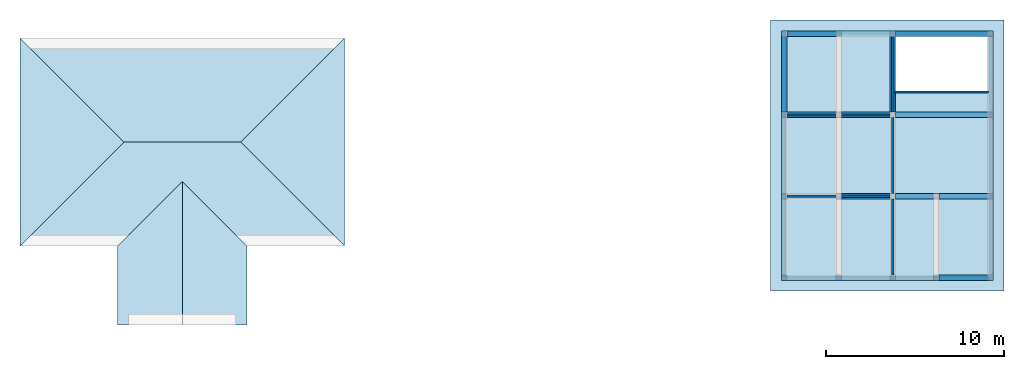
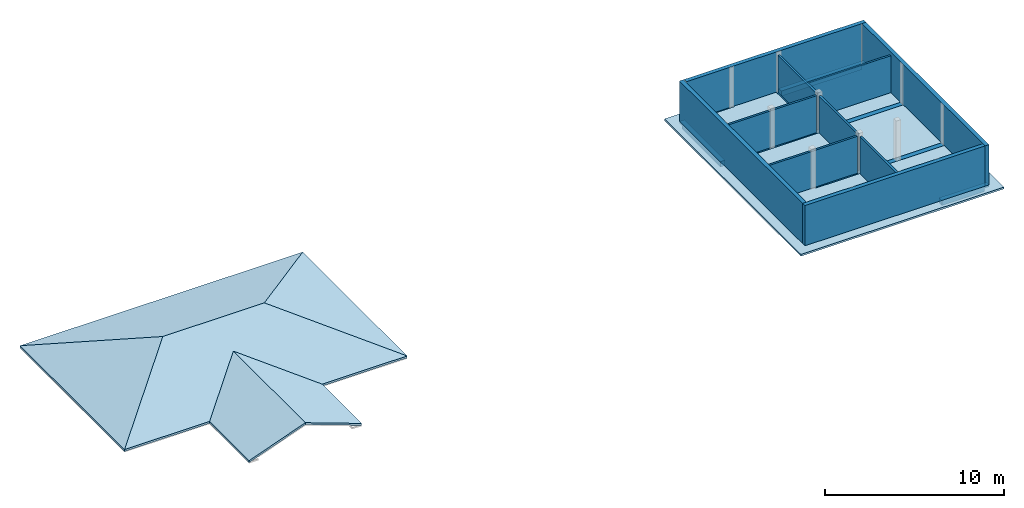
# One storey, part 2 of 3: 11 beams, 10 walls, 7 slabs, 1 opening, 1 element without a shape of its own.
"""IFC2X3 building model written with IfcOpenShell, lengths in feet."""

from ifc_helpers import new_model, entity, si_unit, converted_unit, derived_unit, direction, frame, frame_2d, origin, place, context, subcontext, project, spatial, polyline, rectangle, outline, extrude, faceted_brep, material, layer, layer_set, layer_usage, type_object, element, aggregate, save


model = new_model("IFC2X3")

# Units and contexts
model_context = context("Model", 3, precision=0.0001, world=origin(), true_north=direction((6.123031769111886e-17, 1.0)))
body_context = subcontext(model_context, "Body", "Model", "MODEL_VIEW")
ifc_project = project(units=[converted_unit("LENGTHUNIT", "FOOT", entity("IfcLengthMeasure", 0.3048), si_unit("LENGTHUNIT", "METRE"), dimensions=[1, 0, 0, 0, 0, 0, 0]), converted_unit("AREAUNIT", "SQUARE FOOT", entity("IfcAreaMeasure", 0.09290304), si_unit("AREAUNIT", "SQUARE_METRE"), dimensions=[2, 0, 0, 0, 0, 0, 0]), converted_unit("VOLUMEUNIT", "CUBIC FOOT", entity("IfcVolumeMeasure", 0.028316846592000004), si_unit("VOLUMEUNIT", "CUBIC_METRE"), dimensions=[3, 0, 0, 0, 0, 0, 0]), converted_unit("PLANEANGLEUNIT", "DEGREE", entity("IfcPlaneAngleMeasure", 0.017453292519943278), si_unit("PLANEANGLEUNIT", "RADIAN"), dimensions=[0, 0, 0, 0, 0, 0, 0]), si_unit("MASSUNIT", "GRAM", prefix="KILO"), derived_unit("MASSDENSITYUNIT", [(si_unit("MASSUNIT", "GRAM", prefix="KILO"), 1), (si_unit("LENGTHUNIT", "METRE"), -3)]), derived_unit("IONCONCENTRATIONUNIT", [(si_unit("MASSUNIT", "GRAM", prefix="KILO"), 1), (si_unit("LENGTHUNIT", "METRE"), -3)]), derived_unit("MOMENTOFINERTIAUNIT", [(si_unit("LENGTHUNIT", "METRE"), 4)]), si_unit("TIMEUNIT", "SECOND"), si_unit("FREQUENCYUNIT", "HERTZ"), si_unit("THERMODYNAMICTEMPERATUREUNIT", "DEGREE_CELSIUS"), derived_unit("THERMALTRANSMITTANCEUNIT", [(si_unit("MASSUNIT", "GRAM", prefix="KILO"), 1), (si_unit("THERMODYNAMICTEMPERATUREUNIT", "KELVIN"), -1), (si_unit("TIMEUNIT", "SECOND"), -3)]), derived_unit("THERMALCONDUCTANCEUNIT", [(si_unit("MASSUNIT", "GRAM", prefix="KILO"), 1), (si_unit("THERMODYNAMICTEMPERATUREUNIT", "KELVIN"), -1), (si_unit("TIMEUNIT", "SECOND"), -3), (si_unit("LENGTHUNIT", "METRE"), 1)]), derived_unit("VOLUMETRICFLOWRATEUNIT", [(si_unit("LENGTHUNIT", "METRE"), 3), (si_unit("TIMEUNIT", "SECOND"), -1)]), derived_unit("MASSFLOWRATEUNIT", [(si_unit("MASSUNIT", "GRAM", prefix="KILO"), 1), (si_unit("TIMEUNIT", "SECOND"), -1)]), derived_unit("ROTATIONALFREQUENCYUNIT", [(si_unit("TIMEUNIT", "SECOND"), -1)]), si_unit("ELECTRICCURRENTUNIT", "AMPERE"), si_unit("ELECTRICVOLTAGEUNIT", "VOLT"), si_unit("POWERUNIT", "WATT"), converted_unit("FORCEUNIT", "KIP", entity("IfcForceMeasure", 2.088543423315013e-05), si_unit("FORCEUNIT", "NEWTON"), dimensions=[1, 1, -2, 0, 0, 0, 0]), si_unit("ILLUMINANCEUNIT", "LUX"), si_unit("LUMINOUSFLUXUNIT", "LUMEN"), si_unit("LUMINOUSINTENSITYUNIT", "CANDELA"), si_unit("ENERGYUNIT", "JOULE"), derived_unit("USERDEFINED", [(si_unit("MASSUNIT", "GRAM", prefix="KILO"), -1), (si_unit("LENGTHUNIT", "METRE"), -2), (si_unit("TIMEUNIT", "SECOND"), 3), (si_unit("LUMINOUSFLUXUNIT", "LUMEN"), 1)]), derived_unit("USERDEFINED", [(si_unit("MASSUNIT", "GRAM", prefix="KILO"), 1), (si_unit("TIMEUNIT", "SECOND"), -3), (si_unit("LENGTHUNIT", "METRE"), 3), (si_unit("ELECTRICCURRENTUNIT", "AMPERE"), -2)]), derived_unit("SOUNDPOWERUNIT", [(si_unit("MASSUNIT", "GRAM", prefix="KILO"), 1), (si_unit("TIMEUNIT", "SECOND"), -3), (si_unit("LENGTHUNIT", "METRE"), 2)]), derived_unit("SOUNDPRESSUREUNIT", [(si_unit("MASSUNIT", "GRAM", prefix="KILO"), 1), (si_unit("LENGTHUNIT", "METRE"), -1), (si_unit("TIMEUNIT", "SECOND"), -2)]), derived_unit("LINEARVELOCITYUNIT", [(si_unit("LENGTHUNIT", "METRE"), 1), (si_unit("TIMEUNIT", "SECOND"), -1)]), si_unit("PRESSUREUNIT", "PASCAL"), derived_unit("USERDEFINED", [(si_unit("MASSUNIT", "GRAM", prefix="KILO"), 1), (si_unit("LENGTHUNIT", "METRE"), -2), (si_unit("TIMEUNIT", "SECOND"), -2)]), derived_unit("LINEARFORCEUNIT", [(si_unit("MASSUNIT", "GRAM", prefix="KILO"), 1), (si_unit("TIMEUNIT", "SECOND"), -2)]), derived_unit("PLANARFORCEUNIT", [(si_unit("MASSUNIT", "GRAM", prefix="KILO"), 1), (si_unit("LENGTHUNIT", "METRE"), -1), (si_unit("TIMEUNIT", "SECOND"), -2)]), derived_unit("SPECIFICHEATCAPACITYUNIT", [(si_unit("THERMODYNAMICTEMPERATUREUNIT", "KELVIN"), -1), (si_unit("LENGTHUNIT", "METRE"), 2), (si_unit("TIMEUNIT", "SECOND"), -2)]), derived_unit("HEATFLUXDENSITYUNIT", [(si_unit("MASSUNIT", "GRAM", prefix="KILO"), 1), (si_unit("TIMEUNIT", "SECOND"), -3)]), derived_unit("HEATINGVALUEUNIT", [(si_unit("LENGTHUNIT", "METRE"), 2), (si_unit("TIMEUNIT", "SECOND"), -2)]), derived_unit("VAPORPERMEABILITYUNIT", [(si_unit("LENGTHUNIT", "METRE"), -1), (si_unit("TIMEUNIT", "SECOND"), 1)]), derived_unit("DYNAMICVISCOSITYUNIT", [(si_unit("MASSUNIT", "GRAM", prefix="KILO"), 1), (si_unit("TIMEUNIT", "SECOND"), -1), (si_unit("LENGTHUNIT", "METRE"), -1)]), derived_unit("THERMALEXPANSIONCOEFFICIENTUNIT", [(si_unit("THERMODYNAMICTEMPERATUREUNIT", "KELVIN"), -1)]), derived_unit("MODULUSOFELASTICITYUNIT", [(si_unit("MASSUNIT", "GRAM", prefix="KILO"), 1), (si_unit("LENGTHUNIT", "METRE"), -1), (si_unit("TIMEUNIT", "SECOND"), -2)]), derived_unit("ISOTHERMALMOISTURECAPACITYUNIT", [(si_unit("LENGTHUNIT", "METRE"), 3), (si_unit("MASSUNIT", "GRAM", prefix="KILO"), -1)]), derived_unit("MOISTUREDIFFUSIVITYUNIT", [(si_unit("TIMEUNIT", "SECOND"), -1), (si_unit("LENGTHUNIT", "METRE"), 2)]), derived_unit("MASSPERLENGTHUNIT", [(si_unit("MASSUNIT", "GRAM", prefix="KILO"), 1), (si_unit("LENGTHUNIT", "METRE"), -1)]), derived_unit("THERMALRESISTANCEUNIT", [(si_unit("MASSUNIT", "GRAM", prefix="KILO"), -1), (si_unit("TIMEUNIT", "SECOND"), 3), (si_unit("THERMODYNAMICTEMPERATUREUNIT", "KELVIN"), 1)]), derived_unit("ACCELERATIONUNIT", [(si_unit("LENGTHUNIT", "METRE"), 1), (si_unit("TIMEUNIT", "SECOND"), -2)]), derived_unit("ANGULARVELOCITYUNIT", [(si_unit("TIMEUNIT", "SECOND"), -1), (si_unit("PLANEANGLEUNIT", "RADIAN"), 1)]), derived_unit("LINEARSTIFFNESSUNIT", [(si_unit("MASSUNIT", "GRAM", prefix="KILO"), 1), (si_unit("TIMEUNIT", "SECOND"), -2)]), derived_unit("WARPINGCONSTANTUNIT", [(si_unit("LENGTHUNIT", "METRE"), 6)]), derived_unit("LINEARMOMENTUNIT", [(si_unit("MASSUNIT", "GRAM", prefix="KILO"), 1), (si_unit("LENGTHUNIT", "METRE"), 1), (si_unit("TIMEUNIT", "SECOND"), -2)]), derived_unit("TORQUEUNIT", [(si_unit("MASSUNIT", "GRAM", prefix="KILO"), 1), (si_unit("LENGTHUNIT", "METRE"), 2), (si_unit("TIMEUNIT", "SECOND"), -2)])], contexts=[model_context])

# Site, building, storey
site_placement = place(None, origin())
site = spatial("IfcSite", under=ifc_project, at=site_placement, CompositionType="ELEMENT")
building_placement = place(site_placement, origin())
building = spatial("IfcBuilding", under=site, at=building_placement, CompositionType="ELEMENT")
storey_placement = place(building_placement, frame((0.0, 0.0, 9.416666666668288)))
storey = spatial("IfcBuildingStorey", under=building, at=storey_placement, Name="First Floor", CompositionType="ELEMENT", Elevation=9.416666666668288)

# Beams
ifc_material_1 = material(Name="Concrete, Cast-in-Place gray")
beam_type = type_object("IfcBeamType", PredefinedType="NOTDEFINED")
for number, where in (
    (1, (38.37447801916311, -50.34124484724908, -1.1666666666666714)),
    (2, (20.374478019163327, -35.34124484724902, -1.1666666666666714)),
):
    element("IfcBeam", number, at=place(storey_placement, frame(where)), inside=storey, type_object=beam_type, material=ifc_material_1, context=body_context, shape_type="Brep", body=[
        faceted_brep([(10.0, 0.0, 1.1666666666666643), (10.0, 1.0, 1.1666666666666643), (9.0, 1.0, 1.1666666666666643), (0.0, 1.0, 1.1666666666666643), (0.0, 0.0, 1.1666666666666643), (9.0, 0.0, 1.1666666666666643), (0.0, 0.0, 0.7499999999983835), (0.0, 0.0, 0.0), (9.0, 0.0, 0.0), (9.0, 0.0, 0.7499999999983835), (10.0, 0.0, 0.7499999999983835), (0.0, 1.0, 0.0), (9.0, 1.0, 0.0), (10.0, 1.0, 0.7499999999983835), (9.0, 1.0, 0.7499999999983835), (0.0, 1.0, 0.7499999999983835)], [[[0, 1, 2, 3, 4, 5]], [[0, 5, 4, 6, 7, 8, 9, 10]], [[7, 11, 12, 8]], [[3, 2, 1, 13, 14, 12, 11, 15]], [[1, 0, 10, 13]], [[4, 3, 15, 11, 7, 6]], [[14, 9, 8, 12]], [[9, 14, 13, 10]]]),
    ])
beam_1_placement = place(storey_placement, frame((30.37447801916315, -35.34124484724903, -1.1666666666666732)))
element("IfcBeam", 3, at=beam_1_placement, inside=storey, type_object=beam_type, material=ifc_material_1, context=body_context, shape_type="Brep", body=[
    faceted_brep([(8.0, 0.0, 1.166666666666666), (8.0, 1.0, 1.166666666666666), (7.0, 1.0, 1.166666666666666), (0.0, 1.0, 1.166666666666666), (0.0, 0.0, 1.1666666666666679), (7.0, 0.0, 1.1666666666666679), (0.0, 0.0, 0.7499999999983853), (0.0, 0.0, 0.0), (7.0, 0.0, 0.0), (7.0, 0.0, 0.7499999999983853), (8.0, 0.0, 0.7499999999983853), (0.0, 1.0, 0.0), (7.0, 1.0, 0.0), (8.0, 1.0, 0.7499999999983853), (7.0, 1.0, 0.7499999999983853), (0.0, 1.0, 0.7499999999983853)], [[[0, 1, 2, 3, 4, 5]], [[0, 5, 4, 6, 7, 8, 9, 10]], [[7, 11, 12, 8]], [[3, 2, 1, 13, 14, 12, 11, 15]], [[1, 0, 10, 13]], [[4, 3, 15, 11, 7, 6]], [[14, 9, 8, 12]], [[9, 14, 13, 10]]]),
])
beam_2_placement = place(storey_placement, frame((38.37447801916313, -35.34124484724908, -1.1666666666666714)))
element("IfcBeam", 4, at=beam_2_placement, inside=storey, type_object=beam_type, material=ifc_material_1, context=body_context, shape_type="Brep", body=[
    faceted_brep([(10.0, 0.0, 1.1666666666666643), (10.0, 1.0, 1.1666666666666643), (9.0, 1.0, 1.1666666666666643), (0.0, 1.0, 1.1666666666666643), (0.0, 0.0, 1.1666666666666643), (9.0, 0.0, 1.1666666666666643), (0.0, 0.0, 0.7499999999983835), (0.0, 0.0, 0.0), (9.0, 0.0, 0.0), (9.0, 0.0, 0.7499999999983835), (10.0, 0.0, 0.7499999999983835), (0.0, 1.0, 0.0), (9.0, 1.0, 0.0), (10.0, 1.0, 0.7499999999983835), (9.0, 1.0, 0.7499999999983835), (0.0, 1.0, 0.7499999999983835)], [[[0, 1, 2, 3, 4, 5]], [[0, 5, 4, 6, 7, 8, 9, 10]], [[7, 11, 12, 8]], [[3, 2, 1, 13, 14, 12, 11, 15]], [[1, 0, 10, 13]], [[4, 3, 15, 11, 7, 6]], [[14, 9, 8, 12]], [[9, 14, 13, 10]]]),
])
beam_3_placement = place(storey_placement, frame((9.374478019163147, -20.341244847248984, -1.1666666666666714)))
element("IfcBeam", 5, at=beam_3_placement, inside=storey, type_object=beam_type, material=ifc_material_1, context=body_context, shape_type="Brep", body=[
    faceted_brep([(11.0, 0.0, 1.1666666666666643), (11.0, 1.0, 1.1666666666666643), (10.0, 1.0, 1.1666666666666643), (1.0, 1.0, 1.1666666666666643), (0.0, 1.0, 1.1666666666666643), (0.0, 0.0, 1.1666666666666643), (1.0, 0.0, 1.1666666666666643), (10.0, 0.0, 1.1666666666666643), (0.0, 0.0, 0.7499999999983835), (1.0, 0.0, 0.7499999999983835), (1.0, 0.0, 0.0), (10.0, 0.0, 0.0), (10.0, 0.0, 0.7499999999983835), (11.0, 0.0, 0.7499999999983835), (1.0, 1.0, 0.0), (10.0, 1.0, 0.0), (11.0, 1.0, 0.7499999999983835), (10.0, 1.0, 0.7499999999983835), (1.0, 1.0, 0.7499999999983835), (0.0, 1.0, 0.7499999999983835)], [[[0, 1, 2, 3, 4, 5, 6, 7]], [[0, 7, 6, 5, 8, 9, 10, 11, 12, 13]], [[10, 14, 15, 11]], [[4, 3, 2, 1, 16, 17, 15, 14, 18, 19]], [[1, 0, 13, 16]], [[5, 4, 19, 8]], [[9, 18, 14, 10]], [[18, 9, 8, 19]], [[17, 12, 11, 15]], [[12, 17, 16, 13]]]),
])
beam_4_placement = place(storey_placement, frame((20.374478019163355, -20.341244847249012, -1.1666666666666714)))
element("IfcBeam", 6, at=beam_4_placement, inside=storey, type_object=beam_type, material=ifc_material_1, context=body_context, shape_type="Brep", body=[
    faceted_brep([(10.0, 0.0, 1.1666666666666643), (10.0, 1.0, 1.1666666666666643), (9.0, 1.0, 1.1666666666666643), (0.0, 1.0, 1.1666666666666643), (0.0, 0.0, 1.1666666666666643), (9.0, 0.0, 1.1666666666666643), (0.0, 0.0, 0.7499999999983835), (0.0, 0.0, 0.0), (9.0, 0.0, 0.0), (9.0, 0.0, 0.7499999999983835), (10.0, 0.0, 0.7499999999983835), (0.0, 1.0, 0.0), (9.0, 1.0, 0.0), (10.0, 1.0, 0.7499999999983835), (9.0, 1.0, 0.7499999999983835), (0.0, 1.0, 0.7499999999983835)], [[[0, 1, 2, 3, 4, 5]], [[0, 5, 4, 6, 7, 8, 9, 10]], [[7, 11, 12, 8]], [[3, 2, 1, 13, 14, 12, 11, 15]], [[1, 0, 10, 13]], [[4, 3, 15, 11, 7, 6]], [[14, 9, 8, 12]], [[9, 14, 13, 10]]]),
])
beam_5_placement = place(storey_placement, frame((30.374478019163178, -20.341244847249072, -1.1666666666666732)))
element("IfcBeam", 7, at=beam_5_placement, inside=storey, type_object=beam_type, material=ifc_material_1, context=body_context, shape_type="Brep", body=[
    faceted_brep([(18.0, 0.0, 1.166666666666666), (18.0, 1.0, 1.166666666666666), (17.0, 1.0, 1.166666666666666), (0.0, 1.0, 1.166666666666666), (0.0, 0.0, 1.1666666666666679), (17.0, 0.0, 1.1666666666666679), (0.0, 0.0, 0.7499999999983853), (0.0, 0.0, 0.0), (17.0, 0.0, 0.0), (17.0, 0.0, 0.7499999999983853), (18.0, 0.0, 0.7499999999983853), (0.0, 1.0, 0.0), (17.0, 1.0, 0.0), (18.0, 1.0, 0.7499999999983853), (17.0, 1.0, 0.7499999999983853), (0.0, 1.0, 0.7499999999983853)], [[[0, 1, 2, 3, 4, 5]], [[0, 5, 4, 6, 7, 8, 9, 10]], [[7, 11, 12, 8]], [[3, 2, 1, 13, 14, 12, 11, 15]], [[1, 0, 10, 13]], [[4, 3, 15, 11, 7, 6]], [[14, 9, 8, 12]], [[9, 14, 13, 10]]]),
])
for number, where, z_axis, x_axis in (
    (8, (9.374478019162256, -19.34124484724894, -1.1666666666666732), (0.0, 0.0, 1.0), (0.0, -1.0, 0.0)),
    (9, (29.374478019162254, -19.341244847249, -1.1666666666666732), (0.0, 0.0, 1.0), (0.0, -1.0, 0.0)),
):
    element("IfcBeam", number, at=place(storey_placement, frame(where, z_axis=z_axis, x_axis=x_axis)), inside=storey, type_object=beam_type, material=ifc_material_1, context=body_context, shape_type="Brep", body=[
        faceted_brep([(-15.0, 1.0, 1.166666666666666), (-15.0, 0.0, 1.1666666666666679), (-14.0, 0.0, 1.1666666666666679), (0.0, 0.0, 1.166666666666666), (0.0, 1.0, 1.166666666666666), (-14.0, 1.0, 1.166666666666666), (-15.0, 0.0, 0.7499999999983853), (-14.0, 0.0, 0.7499999999983853), (-14.0, 0.0, 0.0), (0.0, 0.0, 0.0), (0.0, 0.0, 0.7499999999983853), (0.0, 1.0, 0.0), (-14.0, 1.0, 0.0), (0.0, 1.0, 0.7499999999983853), (-14.0, 1.0, 0.7499999999983853), (-15.0, 1.0, 0.7499999999983853)], [[[0, 1, 2, 3, 4, 5]], [[3, 2, 1, 6, 7, 8, 9, 10]], [[11, 9, 8, 12]], [[0, 5, 4, 13, 11, 12, 14, 15]], [[1, 0, 15, 6]], [[4, 3, 10, 9, 11, 13]], [[7, 14, 12, 8]], [[14, 7, 6, 15]]]),
    ])
beam_6_placement = place(storey_placement, frame((10.374478019163183, -5.341244847248929, -1.1666666666666714)))
element("IfcBeam", 10, at=beam_6_placement, inside=storey, type_object=beam_type, material=ifc_material_1, context=body_context, shape_type="Brep", body=[
    faceted_brep([(10.0, 0.0, 1.1666666666666643), (10.0, 1.0, 1.1666666666666643), (9.0, 1.0, 1.1666666666666643), (0.0, 1.0, 1.1666666666666643), (0.0, 0.0, 1.1666666666666643), (9.0, 0.0, 1.1666666666666643), (0.0, 0.0, 0.7499999999983835), (0.0, 0.0, 0.0), (9.0, 0.0, 0.0), (9.0, 0.0, 0.7499999999983835), (10.0, 0.0, 0.7499999999983835), (0.0, 1.0, 0.0), (9.0, 1.0, 0.0), (10.0, 1.0, 0.7499999999983835), (9.0, 1.0, 0.7499999999983835), (0.0, 1.0, 0.7499999999983835)], [[[0, 1, 2, 3, 4, 5]], [[0, 5, 4, 6, 7, 8, 9, 10]], [[7, 11, 12, 8]], [[3, 2, 1, 13, 14, 12, 11, 15]], [[1, 0, 10, 13]], [[4, 3, 15, 11, 7, 6]], [[14, 9, 8, 12]], [[9, 14, 13, 10]]]),
])
beam_7_placement = place(storey_placement, frame((30.374478019163202, -5.341244847249021, -1.1666666666666732)))
element("IfcBeam", 11, at=beam_7_placement, inside=storey, type_object=beam_type, material=ifc_material_1, context=body_context, shape_type="Brep", body=[
    faceted_brep([(18.0, 0.0, 1.166666666666666), (18.0, 1.0, 1.166666666666666), (17.0, 1.0, 1.166666666666666), (0.0, 1.0, 1.166666666666666), (0.0, 0.0, 1.1666666666666679), (17.0, 0.0, 1.1666666666666679), (0.0, 0.0, 0.7499999999983853), (0.0, 0.0, 0.0), (17.0, 0.0, 0.0), (17.0, 0.0, 0.7499999999983853), (18.0, 0.0, 0.7499999999983853), (0.0, 1.0, 0.0), (17.0, 1.0, 0.0), (18.0, 1.0, 0.7499999999983853), (17.0, 1.0, 0.7499999999983853), (0.0, 1.0, 0.7499999999983853)], [[[0, 1, 2, 3, 4, 5]], [[0, 5, 4, 6, 7, 8, 9, 10]], [[7, 11, 12, 8]], [[3, 2, 1, 13, 14, 12, 11, 15]], [[1, 0, 10, 13]], [[4, 3, 15, 11, 7, 6]], [[14, 9, 8, 12]], [[9, 14, 13, 10]]]),
])

# Slab, opening
ifc_material_2 = material(Name="Default Floor")
ifc_layer_1 = layer(ifc_material_2, 0.4166666666666667)
ifc_layer_set_1 = layer_set([ifc_layer_1])
ifc_layer_usage_1 = layer_usage(ifc_layer_set_1, "AXIS3", "POSITIVE", 0.0)
slab_type = type_object("IfcSlabType", PredefinedType="FLOOR", material=ifc_layer_set_1)
slab_1_placement = place(storey_placement, frame((7.374478019162236, -52.34124484724906, -0.4166666666666661)))
slab_1 = element("IfcSlab", 12, at=slab_1_placement, inside=storey, type_object=slab_type, material=ifc_layer_usage_1, PredefinedType="FLOOR", context=body_context, shape_type="SweptSolid", body=[
    extrude(rectangle(XDim=50.00000000000018, YDim=42.99999999999993, at=frame_2d((0.0, 0.0), x_axis=(0.0, -1.0))), frame((21.499999999999968, 25.0, 0.4166666666666661), z_axis=(0.0, 0.0, -1.0), x_axis=(-1.0, 0.0, 0.0)), (0.0, 0.0, 1.0), 0.4166666666666661),
])
opening_placement = place(slab_1_placement, origin())
element("IfcOpeningElement", 13, at=opening_placement, cuts=slab_1, ObjectType="Opening", context=body_context, shape_type="SweptSolid", body=[
    extrude(rectangle(XDim=17.45833333333335, YDim=10.208333333333321, at=frame_2d((3.552713678800501e-15, 4.440892098500626e-16), x_axis=(1.0, 0.0))), frame((31.43749999999999, 42.06250000000006, 0.4166666666666661), z_axis=(0.0, 0.0, -1.0), x_axis=(1.0, 0.0, 0.0)), (0.0, 0.0, 1.0), 0.4166666666666667),
])

# Roof, slabs
ifc_material_3 = material(Name="Default Roof")
ifc_layer_2 = layer(ifc_material_3, 0.4166666666666667)
ifc_layer_set_2 = layer_set([ifc_layer_2])
roof_placement = place(storey_placement, frame((-131.00963252206233, -58.51742434521192, -0.7279404685324042)))
roof = element("IfcRoof", 14, at=roof_placement, inside=storey, material=ifc_layer_set_2, ShapeType="NOTDEFINED")
type_product = type_object("IfcTypeProduct")
slab_2_placement = place(roof_placement, origin())
slab_2 = element("IfcSlab", 15, at=slab_2_placement, type_object=type_product, material=ifc_layer_set_2, PredefinedType="ROOF", context=body_context, shape_type="SweptSolid", body=[
    extrude(outline(polyline([(29.91666666666667, 10.198370319560782), (-29.9166666666666, 10.198370319560965), (-10.750000000000014, -10.198370319560842), (10.75, -10.198370319560846), (29.91666666666667, 10.198370319560782)])), frame((29.916666666666657, 43.250000000000036, 3.488048078384443), z_axis=(0.0, 0.34202014332566755, 0.9396926207859089), x_axis=(1.0, 0.0, 0.0)), (0.0, -0.34202014332566755, 0.9396926207859089), 0.443407405198295),
])
slab_3_placement = place(roof_placement, origin())
slab_3 = element("IfcSlab", 16, at=slab_3_placement, type_object=type_product, material=ifc_layer_set_2, PredefinedType="ROOF", context=body_context, shape_type="SweptSolid", body=[
    extrude(outline(polyline([(-10.198370319560777, 19.166666666666746), (-10.198370319560835, -19.166666666666703), (10.198370319560789, 0.0), (-10.198370319560777, 19.166666666666746)])), frame((9.583333333333343, 33.66666666666677, 3.4880480783844305), z_axis=(-0.3420201433256687, 0.0, 0.9396926207859084), x_axis=(0.9396926207859084, 0.0, 0.3420201433256687)), (0.3420201433256687, 0.0, 0.9396926207859084), 0.443407405198295),
])
slab_4_placement = place(roof_placement, origin())
slab_4 = element("IfcSlab", 17, at=slab_4_placement, type_object=type_product, material=ifc_layer_set_2, PredefinedType="ROOF", context=body_context, shape_type="SweptSolid", body=[
    extrude(outline(polyline([(11.916666666666671, -10.198370319560835), (29.91666666666667, -10.198370319560835), (10.75, 10.198370319560823), (-10.750000000000014, 10.198370319560839), (-29.916666666666657, -10.198370319560768), (-11.916666666666643, -10.198370319560826), (0.0, 2.4830814691104415), (11.916666666666671, -10.198370319560835)])), frame((29.916666666666657, 24.083333333333343, 3.488048078384443), z_axis=(0.0, -0.3420201433256687, 0.9396926207859084), x_axis=(1.0, 0.0, 0.0)), (0.0, 0.3420201433256687, 0.9396926207859084), 0.443407405198295),
])
slab_5_placement = place(roof_placement, origin())
slab_5 = element("IfcSlab", 18, at=slab_5_placement, type_object=type_product, material=ifc_layer_set_2, PredefinedType="ROOF", context=body_context, shape_type="SweptSolid", body=[
    extrude(outline(polyline([(-6.340725894335669, -13.208333333333327), (6.340725894335623, -13.20833333333333), (6.340725894335638, 13.208333333333327), (-6.340725894335638, 1.29166666666668), (-6.340725894335669, -13.208333333333327)])), frame((23.958333333333343, 13.208333333333329, 2.168655979169456), z_axis=(-0.3420201433256687, 0.0, 0.9396926207859084), x_axis=(0.9396926207859084, 0.0, 0.3420201433256687)), (0.3420201433256687, 0.0, 0.9396926207859084), 0.443407405198295),
])
slab_6_placement = place(roof_placement, origin())
slab_6 = element("IfcSlab", 19, at=slab_6_placement, type_object=type_product, material=ifc_layer_set_2, PredefinedType="ROOF", context=body_context, shape_type="SweptSolid", body=[
    extrude(outline(polyline([(6.340725894335638, -13.208333333333329), (6.340725894335638, 1.2916666666666714), (-6.340725894335638, 13.208333333333329), (-6.3407258943356535, -13.208333333333329), (6.340725894335638, -13.208333333333329)])), frame((35.875, 13.208333333333329, 2.168655979169456), z_axis=(0.3420201433256687, 0.0, 0.9396926207859084), x_axis=(0.9396926207859084, 0.0, -0.3420201433256687)), (-0.3420201433256687, 0.0, 0.9396926207859084), 0.443407405198295),
])
slab_7_placement = place(roof_placement, origin())
slab_7 = element("IfcSlab", 20, at=slab_7_placement, type_object=type_product, material=ifc_layer_set_2, PredefinedType="ROOF", context=body_context, shape_type="SweptSolid", body=[
    extrude(outline(polyline([(10.198370319560835, -19.16666666666666), (10.198370319560835, 19.16666666666666), (-10.19837031956082, 0.0), (10.198370319560835, -19.16666666666666)])), frame((50.249999999999986, 33.66666666666666, 3.4880480783844394), z_axis=(0.3420201433256687, 0.0, 0.9396926207859084), x_axis=(0.9396926207859084, 0.0, -0.3420201433256687)), (-0.3420201433256687, 0.0, 0.9396926207859084), 0.443407405198295),
])
aggregate(roof, [slab_2, slab_3, slab_4, slab_5, slab_6, slab_7])

# Walls
ifc_material_4 = material(Name="Default Wall")
ifc_layer_3 = layer(ifc_material_4, 0.041666666666666664)
ifc_layer_4 = layer(ifc_material_4, 0.75)
ifc_layer_5 = layer(ifc_material_4, 0.041666666666666664)
ifc_layer_set_3 = layer_set([ifc_layer_3, ifc_layer_4, ifc_layer_5])
ifc_layer_usage_2 = layer_usage(ifc_layer_set_3, "AXIS2", "NEGATIVE", 0.4166666666666667)
wall_type_1 = type_object("IfcWallType", PredefinedType="STANDARD", material=ifc_layer_set_3)
wall_1_placement = place(storey_placement, frame((10.37447801916223, -4.757911513915553, 0.0)))
element("IfcWallStandardCase", 21, at=wall_1_placement, inside=storey, type_object=wall_type_1, material=ifc_layer_usage_2, context=body_context, shape_type="SweptSolid", body=[
    extrude(rectangle(XDim=38.00000000000001, YDim=0.8333333333333339, at=frame_2d((19.000000000000004, 0.0), x_axis=(-1.0, 0.0))), origin(), (0.0, 0.0, 1.0), 8.999999999998618),
])
wall_2_placement = place(storey_placement, frame((47.957811352495575, -5.174578180582336, 0.0), z_axis=(0.0, 0.0, 1.0), x_axis=(0.0, -1.0, 0.0)))
element("IfcWallStandardCase", 22, at=wall_2_placement, inside=storey, type_object=wall_type_1, material=ifc_layer_usage_2, context=body_context, shape_type="SweptSolid", body=[
    extrude(rectangle(XDim=45.16666666666672, YDim=0.8333333333333286, at=frame_2d((22.58333333333336, -6.38378239159465e-16), x_axis=(-1.0, 0.0))), origin(), (0.0, 0.0, 1.0), 8.999999999998618),
])
wall_3_placement = place(storey_placement, frame((47.54114468582883, -49.924578180582394, 0.0), z_axis=(0.0, 0.0, 1.0), x_axis=(-1.0, 0.0, 0.0)))
element("IfcWallStandardCase", 23, at=wall_3_placement, inside=storey, type_object=wall_type_1, material=ifc_layer_usage_2, context=body_context, shape_type="SweptSolid", body=[
    extrude(rectangle(XDim=38.16666666666667, YDim=0.8333333333333286, at=frame_2d((19.083333333333336, -1.3600232051658168e-15), x_axis=(-1.0, 0.0))), origin(), (0.0, 0.0, 1.0), 8.999999999998618),
])
wall_4_placement = place(storey_placement, frame((9.79114468582883, -49.507911513915595, 0.0), z_axis=(0.0, 0.0, 1.0), x_axis=(0.0, 1.0, 0.0)))
element("IfcWallStandardCase", 24, at=wall_4_placement, inside=storey, type_object=wall_type_1, material=ifc_layer_usage_2, context=body_context, shape_type="SweptSolid", body=[
    extrude(rectangle(XDim=45.166666666666714, YDim=0.8333333333333321, at=frame_2d((22.583333333333357, 2.220446049250313e-16), x_axis=(-1.0, 0.0))), origin(), (0.0, 0.0, 1.0), 8.999999999998618),
])
ifc_layer_6 = layer(ifc_material_4, 0.4166666666666667)
ifc_layer_set_4 = layer_set([ifc_layer_6])
ifc_layer_usage_3 = layer_usage(ifc_layer_set_4, "AXIS2", "NEGATIVE", 0.20833333333333334)
wall_type_2 = type_object("IfcWallType", PredefinedType="STANDARD", material=ifc_layer_set_4)
wall_5_placement = place(storey_placement, frame((10.37447801916221, -19.841244847248937, 0.0)))
element("IfcWallStandardCase", 25, at=wall_5_placement, inside=storey, type_object=wall_type_2, material=ifc_layer_usage_3, context=body_context, shape_type="SweptSolid", body=[
    extrude(rectangle(XDim=19.0, YDim=0.4166666666666643, at=frame_2d((9.5, 0.0), x_axis=(-1.0, 0.0))), origin(), (0.0, 0.0, 1.0), 8.249999999998618),
])
wall_6_placement = place(storey_placement, frame((29.87447801916221, -19.341244847248994, 0.0), z_axis=(0.0, 0.0, 1.0), x_axis=(0.0, 1.0, 0.0)))
element("IfcWallStandardCase", 26, at=wall_6_placement, inside=storey, type_object=wall_type_2, material=ifc_layer_usage_3, context=body_context, shape_type="SweptSolid", body=[
    extrude(rectangle(XDim=14.000000000000046, YDim=0.4166666666666643, at=frame_2d((7.000000000000023, 0.0), x_axis=(-1.0, 0.0))), origin(), (0.0, 0.0, 1.0), 8.249999999998618),
])
wall_7_placement = place(storey_placement, frame((29.87447801916221, -20.341244847249, 0.0), z_axis=(0.0, 0.0, 1.0), x_axis=(0.0, -1.0, 0.0)))
element("IfcWallStandardCase", 27, at=wall_7_placement, inside=storey, type_object=wall_type_2, material=ifc_layer_usage_3, context=body_context, shape_type="SweptSolid", body=[
    extrude(rectangle(XDim=13.999999999999986, YDim=0.4166666666666643, at=frame_2d((6.999999999999993, 0.0), x_axis=(-1.0, 0.0))), origin(), (0.0, 0.0, 1.0), 8.249999999998618),
])
wall_8_placement = place(storey_placement, frame((29.37447801916219, -34.841244847248994, 0.0), z_axis=(0.0, 0.0, 1.0), x_axis=(-1.0, 0.0, 0.0)))
element("IfcWallStandardCase", 28, at=wall_8_placement, inside=storey, type_object=wall_type_2, material=ifc_layer_usage_3, context=body_context, shape_type="SweptSolid", body=[
    extrude(rectangle(XDim=19.000000000000007, YDim=0.4166666666666714, at=frame_2d((9.500000000000004, 0.0), x_axis=(-1.0, 0.0))), origin(), (0.0, 0.0, 1.0), 8.249999999998618),
])
wall_9_placement = place(storey_placement, frame((29.87447801916219, -35.341244847249, 0.0), z_axis=(0.0, 0.0, 1.0), x_axis=(0.0, -1.0, 0.0)))
element("IfcWallStandardCase", 29, at=wall_9_placement, inside=storey, type_object=wall_type_2, material=ifc_layer_usage_3, context=body_context, shape_type="SweptSolid", body=[
    extrude(rectangle(XDim=13.999999999999986, YDim=0.4166666666666643, at=frame_2d((6.999999999999993, 0.0), x_axis=(-1.0, 0.0))), origin(), (0.0, 0.0, 1.0), 8.249999999998618),
])
wall_10_placement = place(storey_placement, frame((30.082811352495554, -15.591244847248992, 0.0)))
element("IfcWallStandardCase", 30, at=wall_10_placement, inside=storey, type_object=wall_type_2, material=ifc_layer_usage_3, context=body_context, shape_type="SweptSolid", body=[
    extrude(rectangle(XDim=17.458333333333336, YDim=0.41666666666666785, at=frame_2d((8.729166666666668, -1.3877787807814457e-16), x_axis=(-1.0, 0.0))), origin(), (0.0, 0.0, 1.0), 8.249999999998618),
])

save(model, "model.ifc")
